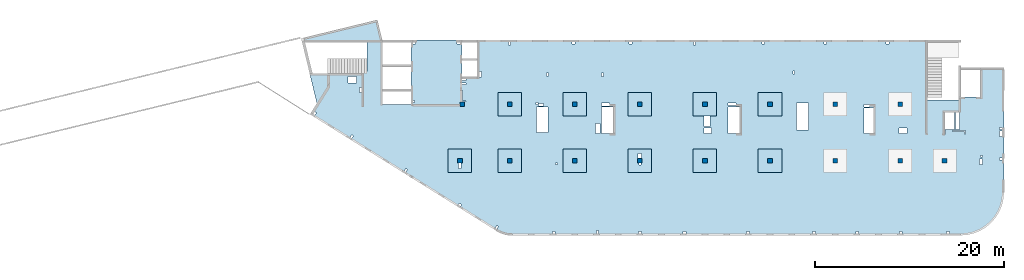
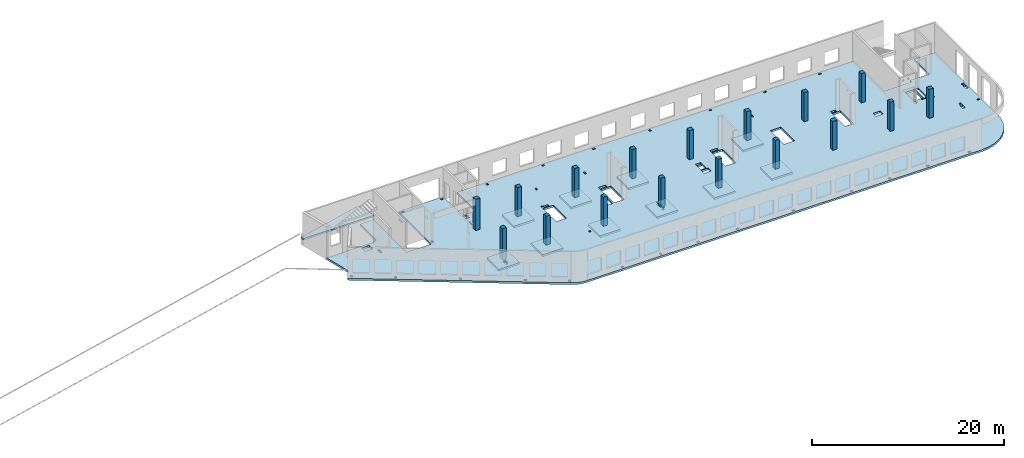
# One storey, part 1 of 7: 17 columns, 13 slabs.
"""IFC4 building model written with IfcOpenShell, lengths in millimetres."""

from ifc_helpers import new_model, entity, si_unit, converted_unit, derived_unit, direction, frame, origin, place, context, subcontext, project, spatial, indexed_curve, outline, extrude, source, transform, mapped, material, type_object, type_shapes, element, save


model = new_model("IFC4")

# Units and contexts
model_context = context("Model", 3, precision=0.01, world=origin(), true_north=direction((6.12303176911189e-17, 1.0)))
plan_context = context("Plan", 3, precision=0.01, world=origin(), true_north=direction((6.12303176911189e-17, 1.0)))
body_context = subcontext(model_context, "Body", "Model", "MODEL_VIEW")
ifc_project = project(units=[si_unit("LENGTHUNIT", "METRE", prefix="MILLI"), si_unit("AREAUNIT", "SQUARE_METRE"), si_unit("VOLUMEUNIT", "CUBIC_METRE"), converted_unit("PLANEANGLEUNIT", "DEGREE", entity("IfcRatioMeasure", 0.0174532925199433), si_unit("PLANEANGLEUNIT", "RADIAN"), dimensions=[0, 0, 0, 0, 0, 0, 0]), si_unit("MASSUNIT", "GRAM", prefix="KILO"), derived_unit("MASSDENSITYUNIT", [(si_unit("MASSUNIT", "GRAM", prefix="KILO"), 1), (si_unit("LENGTHUNIT", "METRE"), -3)]), derived_unit("MOMENTOFINERTIAUNIT", [(si_unit("LENGTHUNIT", "METRE"), 4)]), si_unit("TIMEUNIT", "SECOND"), si_unit("FREQUENCYUNIT", "HERTZ"), si_unit("THERMODYNAMICTEMPERATUREUNIT", "DEGREE_CELSIUS"), derived_unit("THERMALTRANSMITTANCEUNIT", [(si_unit("MASSUNIT", "GRAM", prefix="KILO"), 1), (si_unit("THERMODYNAMICTEMPERATUREUNIT", "KELVIN"), -1), (si_unit("TIMEUNIT", "SECOND"), -3)]), derived_unit("VOLUMETRICFLOWRATEUNIT", [(si_unit("LENGTHUNIT", "METRE"), 3), (si_unit("TIMEUNIT", "SECOND"), -1)]), derived_unit("MASSFLOWRATEUNIT", [(si_unit("MASSUNIT", "GRAM", prefix="KILO"), 1), (si_unit("TIMEUNIT", "SECOND"), -1)]), derived_unit("ROTATIONALFREQUENCYUNIT", [(si_unit("TIMEUNIT", "SECOND"), -1)]), si_unit("ELECTRICCURRENTUNIT", "AMPERE"), si_unit("ELECTRICVOLTAGEUNIT", "VOLT"), si_unit("POWERUNIT", "WATT"), si_unit("FORCEUNIT", "NEWTON", prefix="KILO"), si_unit("ILLUMINANCEUNIT", "LUX"), si_unit("LUMINOUSFLUXUNIT", "LUMEN"), si_unit("LUMINOUSINTENSITYUNIT", "CANDELA"), derived_unit("USERDEFINED", [(si_unit("MASSUNIT", "GRAM", prefix="KILO"), -1), (si_unit("LENGTHUNIT", "METRE"), -2), (si_unit("TIMEUNIT", "SECOND"), 3), (si_unit("LUMINOUSFLUXUNIT", "LUMEN"), 1)]), derived_unit("LINEARVELOCITYUNIT", [(si_unit("LENGTHUNIT", "METRE"), 1), (si_unit("TIMEUNIT", "SECOND"), -1)]), si_unit("PRESSUREUNIT", "PASCAL"), derived_unit("USERDEFINED", [(si_unit("LENGTHUNIT", "METRE"), -2), (si_unit("MASSUNIT", "GRAM", prefix="KILO"), 1), (si_unit("TIMEUNIT", "SECOND"), -2)]), derived_unit("LINEARFORCEUNIT", [(si_unit("MASSUNIT", "GRAM", prefix="KILO"), 1), (si_unit("LENGTHUNIT", "METRE"), 1), (si_unit("TIMEUNIT", "SECOND"), -2), (si_unit("LENGTHUNIT", "METRE"), -1)]), derived_unit("PLANARFORCEUNIT", [(si_unit("MASSUNIT", "GRAM", prefix="KILO"), 1), (si_unit("LENGTHUNIT", "METRE"), 1), (si_unit("TIMEUNIT", "SECOND"), -2), (si_unit("LENGTHUNIT", "METRE"), -2)])], contexts=[model_context, plan_context])

# Site, building, storey
site_placement = place(None, origin())
site = spatial("IfcSite", under=ifc_project, at=site_placement, CompositionType="ELEMENT")
building_placement = place(site_placement, origin())
building = spatial("IfcBuilding", under=site, at=building_placement, CompositionType="ELEMENT")
storey_placement = place(building_placement, frame((0.0, 0.0, 24000.0)))
storey = spatial("IfcBuildingStorey", under=building, at=storey_placement, Name="07", CompositionType="ELEMENT", Elevation=24000.0)

# Columns
ifc_material = material()
column_type_1 = type_object("IfcColumnType", PredefinedType="COLUMN", material=ifc_material)
shared_shape_1 = source(origin(), body_context, "Body", "SweptSolid", [
    extrude(outline(indexed_curve([(-249.999999999999, -249.999999999999), (249.999999999999, -249.999999999999), (249.999999999999, 249.999999999999), (-249.999999999999, 249.999999999999), (-249.999999999999, -249.999999999999)], self_intersect=False)), frame((16150.0, 13700.0, 23850.0), z_axis=(0.0, 0.0, 1.0), x_axis=(0.0, -1.0, 0.0)), (0.0, 0.0, 1.0), 3950.0),
])
type_shapes(column_type_1, [shared_shape_1])
placement_1 = place(storey_placement, frame((0.0, 0.0, -24000.0)))
element("IfcColumn", 1, at=placement_1, inside=storey, type_object=column_type_1, PredefinedType="COLUMN", context=body_context, shape_type="MappedRepresentation", body=[
    mapped(shared_shape_1, transform((0.0, 0.0, 0.0), scale=1.0)),
])
column_type_2 = type_object("IfcColumnType", PredefinedType="COLUMN", material=ifc_material)
shared_shape_2 = source(origin(), body_context, "Body", "SweptSolid", [
    extrude(outline(indexed_curve([(-249.999999999999, -249.999999999999), (250.000000000001, -249.999999999999), (249.999999999999, 249.999999999999), (-250.000000000001, 249.999999999999), (-249.999999999999, -249.999999999999)], self_intersect=False)), frame((15900.0, 7700.0, 23850.0), z_axis=(0.0, 0.0, 1.0), x_axis=(0.0, -1.0, 0.0)), (0.0, 0.0, 1.0), 3950.0),
])
type_shapes(column_type_2, [shared_shape_2])
element("IfcColumn", 2, at=placement_1, inside=storey, type_object=column_type_2, PredefinedType="COLUMN", context=body_context, shape_type="MappedRepresentation", body=[
    mapped(shared_shape_2, transform((0.0, 0.0, 0.0), scale=1.0)),
])
column_type_3 = type_object("IfcColumnType", PredefinedType="COLUMN", material=ifc_material)
shared_shape_3 = source(origin(), body_context, "Body", "SweptSolid", [
    extrude(outline(indexed_curve([(-250.0, -250.0), (250.0, -250.0), (250.0, 250.0), (-250.0, 250.0), (-250.0, -250.0)], self_intersect=False)), frame((0.0, 0.0, 23850.0), z_axis=(0.0, 0.0, 1.0), x_axis=(0.0, -1.0, 0.0)), (0.0, 0.0, 1.0), 3700.0),
])
type_shapes(column_type_3, [shared_shape_3])
for number, where in (
    (3, (21170.0, 7700.0, -24000.0)),
    (4, (28070.0, 7700.0, -24000.0)),
    (5, (34970.0, 7700.0, -24000.0)),
    (6, (41870.0, 7700.0, -24000.0)),
    (7, (48770.0, 7700.0, -24000.0)),
    (8, (55670.0, 7700.0, -24000.0)),
    (9, (62570.0, 7700.0, -24000.0)),
    (10, (67270.0, 7700.0, -24000.0)),
    (11, (62570.0, 13700.0, -24000.0)),
    (12, (55670.0, 13700.0, -24000.0)),
    (13, (48770.0, 13700.0, -24000.0)),
    (14, (41870.0, 13700.0, -24000.0)),
    (15, (34970.0, 13700.0, -24000.0)),
    (16, (28070.0, 13700.0, -24000.0)),
    (17, (21170.0, 13700.0, -24000.0)),
):
    element("IfcColumn", number, at=place(storey_placement, frame(where)), inside=storey, type_object=column_type_3, PredefinedType="COLUMN", context=body_context, shape_type="MappedRepresentation", body=[
        mapped(shared_shape_3, transform((0.0, 0.0, 0.0), scale=1.0)),
    ])

# Slabs
slab_type_1 = type_object("IfcSlabType", Name=":ADSK_ 25_250", PredefinedType="FLOOR", material=ifc_material)
placement_2 = place(storey_placement, origin())
element("IfcSlab", 18, at=placement_2, inside=storey, type_object=slab_type_1, material=ifc_material, Name=":ADSK_ 25_250", ObjectType=":ADSK_ 25_250", PredefinedType="FLOOR", context=body_context, shape_type="SweptSolid", body=[
    extrude(outline(indexed_curve([(-4603.53286028, -15653.7908371281), (-4449.01513314947, -15744.4716102884), (-4289.66236892735, -15826.3582829116), (-4125.97455687157, -15899.1939253055), (-3958.46528799564, -15962.7500065188), (-3787.66014361249, -16016.8271113857), (-3614.09504625731, -16061.2555662162), (-3438.31457816345, -16095.8959711683), (-3260.87027256743, -16120.6396376323), (-3082.31888320434, -16135.4089292555), (-2903.22063742329, -16140.1575055354), (44597.126521692, -16140.1575055355), (45316.7249329339, -16083.5238823425), (46018.6044430807, -15915.0175205227), (46685.4824491883, -15638.7876059446), (47300.9382015049, -15261.6358358598), (47849.817136828, -14792.8489385425), (48318.6040341452, -14243.9700032194), (48695.75580423, -13628.5142509028), (48971.9857188081, -12961.6362447953), (49140.4920806279, -12259.7567346484), (49197.1257038209, -11540.1583234066), (49197.125703821, 1629.84249446453), (46697.125703821, 1629.84249446453), (46697.1257038209, -1470.15750553546), (44397.1265216921, -1470.15750553546), (44397.1265216921, -1810.15750553546), (41057.1265216921, -1810.15750553545), (41057.1265216921, 4559.84313383174), (-6647.87347830793, 4559.8431338319), (-6647.87347830794, 659.842494464898), (-8272.87347830793, 659.842494464902), (-8272.87347830792, 4559.84313383174), (-13672.8734783079, 4559.84313383175), (-13672.8734783079, -2290.15750553506), (-16672.8734783079, -2290.15750553505), (-16672.8734783079, 4559.84313383174), (-18302.8734783079, 4559.84313383174), (-18302.8734783079, 1219.84313383174), (-18622.8734783079, 1219.84313383174), (-18622.8734783079, 1019.84249446499), (-24402.3399879828, 1019.84249446501), (-23636.4879258287, -2121.97831515316), (-24373.0138341888, -3300.68916159189), (-4603.53286028, -15653.7908371281)], self_intersect=False), holes=[indexed_curve([(-19412.8734783079, 19.8424944649914), (-20312.8734783079, 19.8424944649914), (-20312.8734783079, 719.842494464993), (-19412.8734783079, 719.84249446499), (-19412.8734783079, 19.8424944649914)], self_intersect=False), indexed_curve([(-18872.8734783079, -455.157505535005), (-18872.8734783079, -1015.15750553501), (-19122.8734783079, -1015.15750553501), (-19122.8734783079, -455.157505535005), (-18872.8734783079, -455.157505535005)], self_intersect=False), indexed_curve([(-23853.6420978495, -3035.63633762671), (-23684.031549094, -3141.61870290911), (-23843.0050970176, -3396.03452604239), (-24012.6156457731, -3290.05216075998), (-23853.6420978495, -3035.63633762671)], self_intersect=False), indexed_curve([(-19944.1189490349, -5478.52985738614), (-19774.5084002794, -5584.51222266855), (-19933.481948203, -5838.92804580182), (-20103.0924969585, -5732.94568051942), (-19944.1189490349, -5478.52985738614)], self_intersect=False), indexed_curve([(-14211.2824010985, -9060.73380393143), (-14041.671852343, -9166.71616921384), (-14200.6454002666, -9421.13199234711), (-14370.2559490221, -9315.14962706471), (-14211.2824010985, -9060.73380393143)], self_intersect=False), indexed_curve([(-8539.91756324108, -12722.4439065904), (-8285.50174010781, -12881.417454514), (-8391.48410539021, -13051.0280032695), (-8645.89992852348, -12892.0544553459), (-8539.91756324108, -12722.4439065904)], self_intersect=False), indexed_curve([(-4568.92270434749, -15085.8312702362), (-4399.31215559197, -15191.8136355186), (-4558.28570351558, -15446.2294586518), (-4727.89625227109, -15340.2470933694), (-4568.92270434749, -15085.8312702362)], self_intersect=False), indexed_curve([(1627.12652169203, -15940.1575055352), (1327.12652169203, -15940.1575055352), (1327.12652169203, -15740.1575055352), (1627.12652169203, -15740.1575055352), (1627.12652169203, -15940.1575055352)], self_intersect=False), indexed_curve([(6222.12652169204, -15940.1575055352), (6022.12652169204, -15940.1575055352), (6022.12652169204, -15640.1575055352), (6222.12652169204, -15640.1575055352), (6222.12652169204, -15940.1575055352)], self_intersect=False), indexed_curve([(10747.126521692, -15940.1575055352), (10447.126521692, -15940.1575055352), (10447.126521692, -15740.1575055352), (10747.126521692, -15740.1575055352), (10747.126521692, -15940.1575055352)], self_intersect=False), indexed_curve([(15497.126521692, -15940.1575055352), (15197.126521692, -15940.1575055352), (15197.126521692, -15740.1575055352), (15497.126521692, -15740.1575055352), (15497.126521692, -15940.1575055352)], self_intersect=False), indexed_curve([(22197.126521692, -15940.1575055352), (21897.126521692, -15940.1575055352), (21897.126521692, -15740.1575055352), (22197.126521692, -15740.1575055352), (22197.126521692, -15940.1575055352)], self_intersect=False), indexed_curve([(29197.1265216921, -15940.1575055352), (28897.126521692, -15940.1575055352), (28897.126521692, -15740.1575055352), (29197.1265216921, -15740.1575055352), (29197.1265216921, -15940.1575055352)], self_intersect=False), indexed_curve([(33797.126521692, -15940.1575055352), (33497.1265216921, -15940.1575055352), (33497.1265216921, -15740.1575055352), (33797.1265216921, -15740.1575055352), (33797.126521692, -15940.1575055352)], self_intersect=False), indexed_curve([(38397.1265216921, -15940.1575055353), (38097.126521692, -15940.1575055353), (38097.126521692, -15740.1575055353), (38397.1265216921, -15740.1575055353), (38397.1265216921, -15940.1575055353)], self_intersect=False), indexed_curve([(43397.126521692, -15940.1575055353), (43097.126521692, -15940.1575055353), (43097.126521692, -15740.1575055353), (43397.126521692, -15740.1575055353), (43397.126521692, -15940.1575055353)], self_intersect=False), indexed_curve([(-13172.8734783079, 4359.84313383174), (-13172.8734783079, 4159.84313383174), (-13472.8734783079, 4159.84313383174), (-13472.8734783079, 4359.84313383174), (-13172.8734783079, 4359.84313383174)], self_intersect=False), indexed_curve([(-13272.8734783079, -2040.15750553505), (-13472.8734783079, -2040.15750553505), (-13472.8734783079, -1840.15750553505), (-13272.8734783079, -1840.15750553505), (-13272.8734783079, -2040.15750553505)], self_intersect=False), indexed_curve([(-8772.87347830792, 4359.84313383174), (-8472.87347830792, 4359.84313383174), (-8472.87347830792, 4159.84313383174), (-8772.87347830792, 4159.84313383174), (-8772.87347830792, 4359.84313383174)], self_intersect=False), indexed_curve([(-7842.87347830793, 459.842494464904), (-7842.87347830793, 259.842494464902), (-8272.87347830793, 259.842494464902), (-8272.87347830793, 459.842494464902), (-7842.87347830793, 459.842494464904)], self_intersect=False), indexed_curve([(-7842.87347830793, 34.8424944649014), (-7842.87347830793, -125.157505535097), (-8272.87347830793, -125.157505535097), (-8272.87347830793, 34.8424944649014), (-7842.87347830793, 34.8424944649014)], self_intersect=False), indexed_curve([(-8272.87347830794, -1970.1575055351), (-8272.87347830793, -780.157505535095), (-8192.87347830793, -780.157505535095), (-8192.87347830794, -1890.15750553509), (-7852.87347830794, -1890.15750553509), (-7852.87347830794, -1970.15750553509), (-8272.87347830794, -1970.1575055351)], self_intersect=False), indexed_curve([(-6197.87347830793, 659.842494464898), (-6447.87347830793, 659.842494464898), (-6447.87347830793, 1219.8424944649), (-6197.87347830793, 1219.8424944649), (-6197.87347830793, 659.842494464898)], self_intersect=False), indexed_curve([(-3302.87347830793, 4359.84313383174), (-3202.87347830793, 4359.84313383174), (-3102.87347830793, 4359.84249446488), (-3102.87347830793, 4059.84313383174), (-3302.87347830793, 4059.84313383174), (-3302.87347830793, 4359.84313383174)], self_intersect=False), indexed_curve([(3397.12652169207, 4359.84249446484), (3697.12652169207, 4359.84249446483), (3697.12652169207, 4159.84249446483), (3397.12652169207, 4159.84249446483), (3397.12652169207, 4359.84249446484)], self_intersect=False), indexed_curve([(9472.12652169208, 4359.84249446481), (9772.12652169208, 4359.84249446482), (9772.12652169207, 4159.84249446481), (9472.12652169207, 4159.84249446481), (9472.12652169208, 4359.84249446481)], self_intersect=False), indexed_curve([(23522.1265216921, 4359.84249446477), (23822.1265216921, 4359.84249446476), (23822.1265216921, 4159.84249446476), (23522.1265216921, 4159.84249446477), (23522.1265216921, 4359.84249446477)], self_intersect=False), indexed_curve([(16272.1265216921, 4359.84249446475), (16472.1265216921, 4359.84249446474), (16472.1265216921, 4059.84249446474), (16272.1265216921, 4059.84249446474), (16272.1265216921, 4359.84249446475)], self_intersect=False), indexed_curve([(30097.1265216921, 4359.84249446474), (30397.1265216921, 4359.84249446473), (30397.1265216921, 4159.84249446474), (30097.1265216921, 4159.84249446474), (30097.1265216921, 4359.84249446474)], self_intersect=False), indexed_curve([(36697.1265216921, 4359.84249446472), (36997.1265216921, 4359.84249446471), (36997.1265216921, 4159.84249446472), (36697.1265216921, 4159.84249446472), (36697.1265216921, 4359.84249446472)], self_intersect=False), indexed_curve([(897.126521692066, 1059.84313383174), (897.126521692066, 739.843133831733), (697.126521692064, 739.843133831735), (697.126521692064, 1059.84313383174), (897.126521692066, 1059.84313383174)], self_intersect=False), indexed_curve([(6747.12652169207, 1079.84313383185), (6747.12652169207, 719.843133831856), (6547.12652169207, 719.843133831856), (6547.12652169207, 1079.84313383185), (6747.12652169207, 1079.84313383185)], self_intersect=False), indexed_curve([(26987.1265216921, 1309.84249446548), (26987.1265216921, 959.842494465525), (26837.1265216921, 959.842494465525), (26837.1265216921, 1309.84249446548), (26987.1265216921, 1309.84249446548)], self_intersect=False), indexed_curve([(44067.1265216921, -4915.15750553544), (44067.1265216921, -3110.15750553544), (44457.1265216921, -3110.15750553545), (44457.1265216921, -4915.15750553544), (44067.1265216921, -4915.15750553544)], self_intersect=False), indexed_curve([(42987.1265216921, -5035.15750553544), (42987.1265216921, -5375.15750553544), (42907.1265216921, -5375.15750553545), (42907.1265216921, -5315.1575055354), (42907.1265216921, -5035.15750553544), (42987.1265216921, -5035.15750553544)], self_intersect=False), indexed_curve([(45107.1265216921, -5035.15750553544), (45107.1265216921, -5375.15750553544), (45027.1265216921, -5375.15750553544), (45027.1265216921, -5115.15750553544), (43727.1265216921, -5115.15750553544), (43727.1265216921, -5035.15750553544), (45107.1265216921, -5035.15750553544)], self_intersect=False), indexed_curve([(48697.1257038209, -8130.15750553549), (48697.1257038209, -7930.15750553549), (48997.1257038209, -7930.15750553549), (48997.1257038209, -8130.15750553549), (48697.1257038209, -8130.15750553549)], self_intersect=False), indexed_curve([(48697.1257038209, -4890.15750553548), (48697.1257038209, -4690.15750553548), (48997.125703821, -4690.15750553549), (48997.125703821, -4890.15750553548), (48697.1257038209, -4890.15750553548)], self_intersect=False), indexed_curve([(48697.1257038209, -5655.1575055355), (48697.1257038209, -5055.15750553549), (48997.1257038209, -5055.15750553549), (48997.125703821, -5655.1575055355), (48697.1257038209, -5655.1575055355)], self_intersect=False), indexed_curve([(46907.1257038209, -8030.15750553448), (46907.1257038209, -8640.15750553548), (46607.1257038209, -8640.15750553548), (46607.1257038209, -8030.15750553448), (46907.1257038209, -8030.15750553448)], self_intersect=False), indexed_curve([(46917.1257038209, -7650.1575055345), (46917.1257038209, -7850.15750553452), (46717.1257038209, -7850.15750553452), (46717.1257038209, -7650.15750553449), (46917.1257038209, -7650.1575055345)], self_intersect=False), indexed_curve([(38912.1265216921, -4755.15750553541), (38912.1265216921, -5355.1575055354), (38082.1265216921, -5355.1575055354), (38082.1265216921, -4755.15750553541), (38912.1265216921, -4755.15750553541)], self_intersect=False), indexed_curve([(34357.1265216921, -5315.15750553539), (34357.1265216921, -2645.15750553538), (35357.1265216921, -2645.15750553538), (35357.1265216921, -5315.1575055354), (34357.1265216921, -5315.15750553539)], self_intersect=False), indexed_curve([(34357.1265216921, -2240.15750553538), (34957.1265216921, -2240.15750553538), (34957.1265216921, -2525.15750553538), (34357.1265216921, -2525.15750553538), (34357.1265216921, -2240.15750553538)], self_intersect=False), indexed_curve([(28477.1265216921, -2105.15750553533), (28477.1265216921, -4965.15750553535), (27217.1265216921, -4965.15750553535), (27217.1265216921, -2105.15750553533), (28477.1265216921, -2105.15750553533)], self_intersect=False), indexed_curve([(19937.1265216921, -5315.1573559755), (19937.1265216921, -2540.1573559755), (21197.1265216921, -2540.1573559755), (21197.1265216921, -5315.15735597549), (19937.1265216921, -5315.1573559755)], self_intersect=False), indexed_curve([(19937.1265216921, -2390.1575055353), (19937.1265216921, -2100.15750553529), (20797.1265216921, -2100.15750553529), (20797.1265216921, -2390.15750553529), (19937.1265216921, -2390.1575055353)], self_intersect=False), indexed_curve([(17407.1265216921, -3490.15750553534), (17497.1265216921, -3490.15750553534), (18027.1265216921, -3490.15750553534), (18027.1265216921, -4610.15750553534), (17407.1265216921, -4610.15750553534), (17407.1265216921, -3490.15750553534)], self_intersect=False), indexed_curve([(17382.1265216921, -4755.15750553535), (18212.1265216921, -4755.15750553535), (18212.1265216921, -5355.15750553534), (17382.1265216921, -5355.15750553534), (17382.1265216921, -4755.15750553535)], self_intersect=False), indexed_curve([(6537.12652169207, -5315.15735597545), (6537.12652169207, -2540.15735597545), (7797.12652169206, -2540.15735597545), (7797.12652169207, -5315.15735597545), (6537.12652169207, -5315.15735597545)], self_intersect=False), indexed_curve([(6537.12652169207, -2100.1575055352), (7397.12652169206, -2100.1575055352), (7397.12652169206, -2420.15750553519), (6537.12652169206, -2420.15750553519), (6537.12652169207, -2100.1575055352)], self_intersect=False), indexed_curve([(5917.12652169207, -5355.15735597546), (5917.12652169206, -4265.15735597545), (6377.12652169207, -4265.15735597545), (6377.12652169207, -5355.15735597546), (5917.12652169207, -5355.15735597546)], self_intersect=False), indexed_curve([(1877.12652169205, -8450.15750553516), (1877.12652169204, -8650.15750553516), (1677.12652169204, -8650.15750553516), (1677.12652169204, -8450.15750553516), (1877.12652169205, -8450.15750553516)], self_intersect=False), indexed_curve([(877.126521692058, -2540.15750553514), (877.126521692058, -5250.15750553514), (-382.873478307942, -5250.15750553514), (-382.873478307942, -2540.15750553514), (877.126521692058, -2540.15750553514)], self_intersect=False), indexed_curve([(-202.873478307996, -2250.15750553514), (-402.87347830802, -2250.15750553514), (-402.873478308024, -2050.15750553452), (-202.873478308, -2050.15750553452), (-202.873478307996, -2250.15750553514)], self_intersect=False), indexed_curve([(397.126521692006, -2420.15750553515), (-162.873478308005, -2420.15750553515), (-162.873478308009, -2170.15750553515), (397.126521692006, -2170.15750553515), (397.126521692006, -2420.15750553515)], self_intersect=False), indexed_curve([(43947.1265216921, -3110.15750553544), (43947.1265216921, -4915.15750553545), (42907.1265216921, -4915.15750553544), (42907.1265216921, -3110.15750553544), (43947.1265216921, -3110.15750553544)], self_intersect=False), indexed_curve([(-8632.87347830795, -8490.15750553509), (-8472.87347830795, -8490.15750553509), (-8382.87347830796, -8490.15750553509), (-8382.87347830795, -9050.15750553509), (-8632.87347830794, -9050.15750553509), (-8632.87347830795, -8490.15750553509)], self_intersect=False), indexed_curve([(10497.1265216921, -8490.15750553522), (10597.126521692, -8490.15750553522), (10697.1265216921, -8490.15750553522), (10697.1265216921, -8690.15750553522), (10497.1265216921, -8690.15750553523), (10497.1265216921, -8490.15750553522)], self_intersect=False), indexed_curve([(10417.126521692, -7950.15750553522), (10417.126521692, -7440.15750553522), (10747.126521692, -7440.15750553522), (10747.126521692, -7950.15750553522), (10417.126521692, -7950.15750553522)], self_intersect=False)]), frame((24372.87, 15940.16, -400.0)), (0.0, 0.0, 1.0), 249.999999999999),
])
slab_type_2 = type_object("IfcSlabType", Name=":ADSK_ 25_200", PredefinedType="FLOOR", material=ifc_material)
element("IfcSlab", 19, at=placement_2, inside=storey, type_object=slab_type_2, material=ifc_material, Name=":ADSK_ 25_200", ObjectType=":ADSK_ 25_200", PredefinedType="FLOOR", context=body_context, shape_type="SweptSolid", body=[
    extrude(outline(indexed_curve([(-2965.94379251259, -516.869103588944), (5577.68320951875, -516.869103588944), (5667.33346675777, -149.08913967664), (-2396.54091108099, 1816.56555403243), (-2916.58818017036, -316.869103588947), (-2965.94379251259, -316.869103588947), (-2965.94379251259, -516.869103588944)], self_intersect=False)), frame((4734.06, 20816.87, 550.0), z_axis=(0.0, 0.0, -1.0), x_axis=(-1.0, 0.0, 0.0)), (0.0, 0.0, 1.0), 200.000000000002),
])
slab_type_3 = type_object("IfcSlabType", Name=":ADSK_ 25_250", PredefinedType="FLOOR", material=ifc_material)
element("IfcSlab", 20, at=placement_2, inside=storey, type_object=slab_type_3, material=ifc_material, Name=":ADSK_ 25_250", ObjectType=":ADSK_ 25_250", PredefinedType="FLOOR", context=body_context, shape_type="SweptSolid", body=[
    extrude(outline(indexed_curve([(-999.999999999999, -1250.0), (1500.0, -1250.0), (1500.0, 1250.0), (-999.999999999999, 1250.0), (-1000.0, -1.73258740687743e-12), (-999.999999999999, -1250.0)], self_intersect=False), holes=[indexed_curve([(500.000000000006, 89.9999999999999), (1060.0, 90.0000000000009), (1060.0, -159.999999999999), (500.000000000007, -160.0), (500.000000000006, 89.9999999999999)], self_intersect=False)]), frame((15900.0, 7950.0, -650.0), z_axis=(0.0, 0.0, 1.0), x_axis=(0.0, -1.0, 0.0)), (0.0, 0.0, 1.0), 249.999999999999),
])
slab_type_4 = type_object("IfcSlabType", Name=":ADSK_ 25_250", PredefinedType="FLOOR", material=ifc_material)
element("IfcSlab", 21, at=placement_2, inside=storey, type_object=slab_type_4, material=ifc_material, Name=":ADSK_ 25_250", ObjectType=":ADSK_ 25_250", PredefinedType="FLOOR", context=body_context, shape_type="SweptSolid", body=[
    extrude(outline(indexed_curve([(-1250.0, -1250.0), (1250.0, -1250.0), (1250.0, 1250.0), (-1250.0, 1250.0), (-1250.0, -1250.0)], self_intersect=False)), frame((21170.0, 7700.0, -400.0), z_axis=(0.0, 0.0, -1.0), x_axis=(0.0, 1.0, 0.0)), (0.0, 0.0, 1.0), 249.999999999999),
])
slab_type_5 = type_object("IfcSlabType", Name=":ADSK_ 25_250", PredefinedType="FLOOR", material=ifc_material)
element("IfcSlab", 22, at=placement_2, inside=storey, type_object=slab_type_5, material=ifc_material, Name=":ADSK_ 25_250", ObjectType=":ADSK_ 25_250", PredefinedType="FLOOR", context=body_context, shape_type="SweptSolid", body=[
    extrude(outline(indexed_curve([(-1250.0, -1250.0), (1250.0, -1250.0), (1250.0, 1250.0), (-1250.0, 1250.0), (-1250.0, -1250.0)], self_intersect=False)), frame((28070.0, 7700.0, -400.0), z_axis=(0.0, 0.0, -1.0), x_axis=(0.0, 1.0, 0.0)), (0.0, 0.0, 1.0), 249.999999999999),
])
slab_type_6 = type_object("IfcSlabType", Name=":ADSK_ 25_250", PredefinedType="FLOOR", material=ifc_material)
element("IfcSlab", 23, at=placement_2, inside=storey, type_object=slab_type_6, material=ifc_material, Name=":ADSK_ 25_250", ObjectType=":ADSK_ 25_250", PredefinedType="FLOOR", context=body_context, shape_type="SweptSolid", body=[
    extrude(outline(indexed_curve([(-999.999999999999, -1250.00000000001), (1500.0, -1250.00000000001), (1500.0, 1250.0), (-999.999999999999, 1250.0), (-1000.0, -6.064055924071e-12), (-999.999999999999, -1250.00000000001)], self_intersect=False), holes=[indexed_curve([(500.000000000073, 99.9999999999998), (700.000000000076, 100.0), (700.000000000076, -100.000000000002), (500.000000000074, -100.000000000002), (500.000000000073, 99.9999999999998)], self_intersect=False), indexed_curve([(-549.999999999928, 149.999999999991), (-39.9999999999262, 149.999999999992), (-39.9999999999256, -180.000000000007), (-549.999999999928, -180.000000000008), (-549.999999999928, 149.999999999991)], self_intersect=False)]), frame((34970.0, 7950.0, -650.0), z_axis=(0.0, 0.0, 1.0), x_axis=(0.0, -1.0, 0.0)), (0.0, 0.0, 1.0), 249.999999999999),
])
slab_type_7 = type_object("IfcSlabType", Name=":ADSK_ 25_250", PredefinedType="FLOOR", material=ifc_material)
element("IfcSlab", 24, at=placement_2, inside=storey, type_object=slab_type_7, material=ifc_material, Name=":ADSK_ 25_250", ObjectType=":ADSK_ 25_250", PredefinedType="FLOOR", context=body_context, shape_type="SweptSolid", body=[
    extrude(outline(indexed_curve([(-1250.0, -1250.0), (1250.0, -1250.0), (1250.0, 1250.0), (-1250.0, 1250.0), (-1250.0, -1250.0)], self_intersect=False)), frame((41870.0, 7700.0, -400.0), z_axis=(0.0, 0.0, -1.0), x_axis=(0.0, 1.0, 0.0)), (0.0, 0.0, 1.0), 249.999999999999),
])
slab_type_8 = type_object("IfcSlabType", Name=":ADSK_ 25_250", PredefinedType="FLOOR", material=ifc_material)
element("IfcSlab", 25, at=placement_2, inside=storey, type_object=slab_type_8, material=ifc_material, Name=":ADSK_ 25_250", ObjectType=":ADSK_ 25_250", PredefinedType="FLOOR", context=body_context, shape_type="SweptSolid", body=[
    extrude(outline(indexed_curve([(-1250.0, -1250.0), (1250.0, -1250.0), (1250.0, 1250.0), (-1250.0, 1250.0), (-1250.0, -1250.0)], self_intersect=False)), frame((48770.0, 7700.0, -400.0), z_axis=(0.0, 0.0, -1.0), x_axis=(0.0, 1.0, 0.0)), (0.0, 0.0, 1.0), 249.999999999999),
])
slab_type_9 = type_object("IfcSlabType", Name=":ADSK_ 25_250", PredefinedType="FLOOR", material=ifc_material)
element("IfcSlab", 26, at=placement_2, inside=storey, type_object=slab_type_9, material=ifc_material, Name=":ADSK_ 25_250", ObjectType=":ADSK_ 25_250", PredefinedType="FLOOR", context=body_context, shape_type="SweptSolid", body=[
    extrude(outline(indexed_curve([(-1250.0, -1250.0), (1250.0, -1250.0), (1250.0, 1250.0), (-1250.0, 1250.0), (-1250.0, -1250.0)], self_intersect=False)), frame((48770.0, 13700.0, -400.0), z_axis=(0.0, 0.0, -1.0), x_axis=(0.0, 1.0, 0.0)), (0.0, 0.0, 1.0), 249.999999999999),
])
slab_type_10 = type_object("IfcSlabType", Name=":ADSK_ 25_250", PredefinedType="FLOOR", material=ifc_material)
element("IfcSlab", 27, at=placement_2, inside=storey, type_object=slab_type_10, material=ifc_material, Name=":ADSK_ 25_250", ObjectType=":ADSK_ 25_250", PredefinedType="FLOOR", context=body_context, shape_type="SweptSolid", body=[
    extrude(outline(indexed_curve([(-1250.0, -1250.0), (1250.0, -1250.0), (1250.0, 1250.0), (-1250.0, 1250.0), (-1250.0, -1250.0)], self_intersect=False)), frame((41870.0, 13700.0, -400.0), z_axis=(0.0, 0.0, -1.0), x_axis=(0.0, 1.0, 0.0)), (0.0, 0.0, 1.0), 249.999999999999),
])
slab_type_11 = type_object("IfcSlabType", Name=":ADSK_ 25_250", PredefinedType="FLOOR", material=ifc_material)
element("IfcSlab", 28, at=placement_2, inside=storey, type_object=slab_type_11, material=ifc_material, Name=":ADSK_ 25_250", ObjectType=":ADSK_ 25_250", PredefinedType="FLOOR", context=body_context, shape_type="SweptSolid", body=[
    extrude(outline(indexed_curve([(-1250.0, -1250.0), (1250.0, -1250.0), (1250.0, 1250.0), (-1250.0, 1250.0), (-1250.0, -1250.0)], self_intersect=False)), frame((34970.0, 13700.0, -400.0), z_axis=(0.0, 0.0, -1.0), x_axis=(0.0, 1.0, 0.0)), (0.0, 0.0, 1.0), 249.999999999999),
])
slab_type_12 = type_object("IfcSlabType", Name=":ADSK_ 25_250", PredefinedType="FLOOR", material=ifc_material)
element("IfcSlab", 29, at=placement_2, inside=storey, type_object=slab_type_12, material=ifc_material, Name=":ADSK_ 25_250", ObjectType=":ADSK_ 25_250", PredefinedType="FLOOR", context=body_context, shape_type="SweptSolid", body=[
    extrude(outline(indexed_curve([(-1250.0, -1250.0), (1250.0, -1250.0), (1250.0, 1250.0), (-1250.0, 1250.0), (-1250.0, -1250.0)], self_intersect=False)), frame((28070.0, 13700.0, -400.0), z_axis=(0.0, 0.0, -1.0), x_axis=(0.0, 1.0, 0.0)), (0.0, 0.0, 1.0), 249.999999999999),
])
slab_type_13 = type_object("IfcSlabType", Name=":ADSK_ 25_250", PredefinedType="FLOOR", material=ifc_material)
element("IfcSlab", 30, at=placement_2, inside=storey, type_object=slab_type_13, material=ifc_material, Name=":ADSK_ 25_250", ObjectType=":ADSK_ 25_250", PredefinedType="FLOOR", context=body_context, shape_type="SweptSolid", body=[
    extrude(outline(indexed_curve([(-1250.0, -1250.0), (1250.0, -1250.0), (1250.0, 1250.0), (-1250.0, 1250.0), (-1250.0, -1250.0)], self_intersect=False)), frame((21170.0, 13700.0, -400.0), z_axis=(0.0, 0.0, -1.0), x_axis=(0.0, 1.0, 0.0)), (0.0, 0.0, 1.0), 249.999999999999),
])

save(model, "model.ifc")
